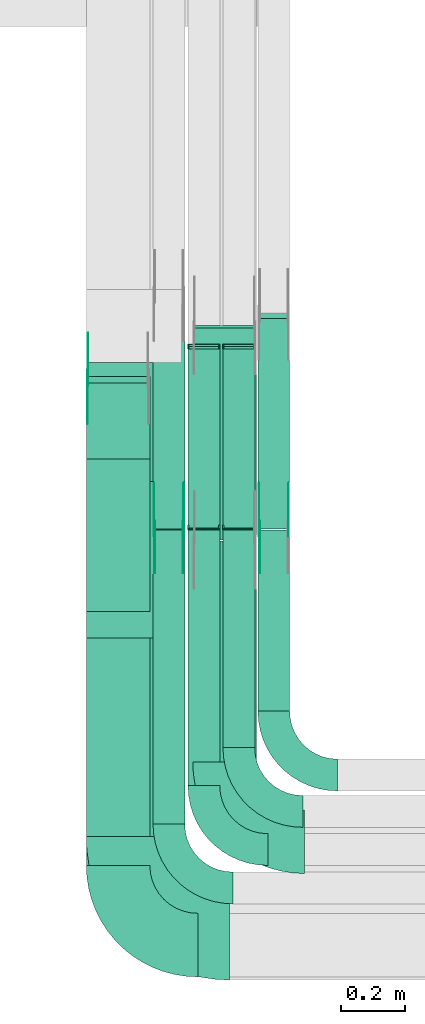
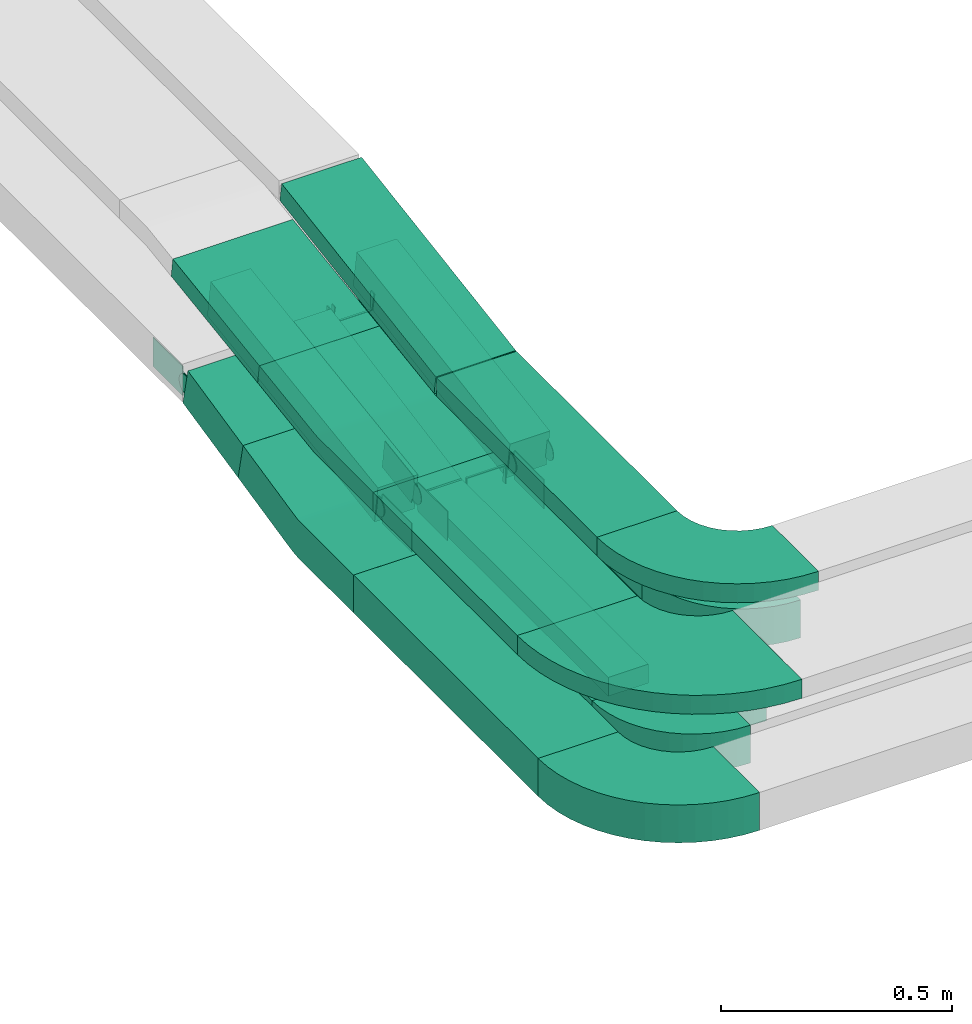
# One storey, part 4 of 28: 22 flow fittings, 14 flow segments.
"""IFC2X3 building model written with IfcOpenShell, lengths in millimetres."""

import ifcopenshell
import ifcopenshell.guid

model = None  # the IFC model being written
_history = None  # IfcOwnerHistory: only IFC2X3 demands one
_inside = {}  # id of a spatial element -> (the spatial element, [elements in it])
_under = {}  # id of a project, library or spatial element -> (it, [spatial elements below it])
_declared = {}  # id of a project -> (the project, [libraries it declares])
_typed = {}  # id of a type object -> (the type object, [elements of that type])
_made_of = {}  # id of a material, layer set ... -> (it, [elements and type objects made of it])


def new_model(schema):
    """Start an empty IFC model of exactly this schema.

    Asked for "IFC4X3", IfcOpenShell would pick the latest addendum, in which some entities
    have other attributes; the version numbers below select the first issue.
    IFC2X3 requires an IfcOwnerHistory on every rooted entity: one is made here for all.
    """
    global model, _history
    if schema == "IFC4X3":
        model = ifcopenshell.file(schema_version=(4, 3, 0, 0))
    else:
        model = ifcopenshell.file(schema=schema)
    _inside.clear()
    _under.clear()
    _declared.clear()
    _typed.clear()
    _made_of.clear()
    _history = None
    if model.schema == "IFC2X3":
        org = make("IfcOrganization", Name="unknown")
        user = make(
            "IfcPersonAndOrganization",
            ThePerson=make("IfcPerson", FamilyName="unknown"),
            TheOrganization=org,
        )
        app = make(
            "IfcApplication",
            ApplicationDeveloper=org,
            Version="unknown",
            ApplicationFullName="unknown",
            ApplicationIdentifier="unknown",
        )
        _history = make(
            "IfcOwnerHistory",
            OwningUser=user,
            OwningApplication=app,
            ChangeAction="ADDED",
            CreationDate=0,
        )
    return model


def make(cls, **values):
    """One entity of the class cls with the attributes given. An attribute that is None is left unset."""
    return model.create_entity(
        cls, **{name: value for name, value in values.items() if value is not None}
    )


def entity(cls, *values):
    """Any entity or typed value of the class cls, its attributes in the order of the schema. None: left unset."""
    e = model.create_entity(cls)
    for i, value in enumerate(values):
        if value is not None:
            e[i] = value
    return e


def rooted(cls, **values):
    """An entity with a GlobalId (a new one), such as an element, a storey or a relation."""
    return make(cls, GlobalId=ifcopenshell.guid.new(), OwnerHistory=_history, **values)


def si_unit(unit_type, name, prefix=None):
    """IfcSIUnit, for example si_unit("LENGTHUNIT", "METRE", prefix="MILLI")."""
    return make("IfcSIUnit", UnitType=unit_type, Prefix=prefix, Name=name)


def converted_unit(unit_type, name, factor, base, dimensions=None, offset=None):
    """IfcConversionBasedUnit, such as the inch: factor (a typed value) times the base unit."""
    return make(
        "IfcConversionBasedUnit"
        if offset is None
        else "IfcConversionBasedUnitWithOffset",
        ConversionOffset=offset,
        Dimensions=None
        if dimensions is None
        else entity("IfcDimensionalExponents", *dimensions),
        UnitType=unit_type,
        Name=name,
        ConversionFactor=make(
            "IfcMeasureWithUnit", ValueComponent=factor, UnitComponent=base
        ),
    )


def derived_unit(unit_type, elements):
    """IfcDerivedUnit: a product of units, each with its exponent."""
    return make(
        "IfcDerivedUnit",
        Elements=[
            make("IfcDerivedUnitElement", Unit=unit, Exponent=power)
            for unit, power in elements
        ],
        UnitType=unit_type,
    )


def assignment(units):
    """IfcUnitAssignment: the units of a project."""
    return None if units is None else make("IfcUnitAssignment", Units=units)


def point(xyz):
    """IfcCartesianPoint."""
    return None if xyz is None else make("IfcCartesianPoint", Coordinates=xyz)


def direction(xyz):
    """IfcDirection."""
    return None if xyz is None else make("IfcDirection", DirectionRatios=xyz)


def frame(location, z_axis=None, x_axis=None):
    """IfcAxis2Placement3D, a coordinate frame: its origin and axes. An axis left out is left unset."""
    return make(
        "IfcAxis2Placement3D",
        Location=point(location),
        Axis=direction(z_axis),
        RefDirection=direction(x_axis),
    )


def frame_2d(location, x_axis=None):
    """IfcAxis2Placement2D, a coordinate frame in the plane: its origin and x axis."""
    return make(
        "IfcAxis2Placement2D", Location=point(location), RefDirection=direction(x_axis)
    )


def origin():
    """The frame at (0, 0, 0) with its axes left unset."""
    return frame((0.0, 0.0, 0.0))


def origin_2d_with_axis():
    """The frame at (0, 0) in the plane with the x axis (1, 0) written out."""
    return frame_2d((0.0, 0.0), x_axis=(1.0, 0.0))


def place(relative_to, where):
    """IfcLocalPlacement: puts the frame where relative to a parent placement (None: the world)."""
    return make(
        "IfcLocalPlacement", PlacementRelTo=relative_to, RelativePlacement=where
    )


def context(
    kind, dimensions, precision=None, world=None, true_north=None, identifier=None
):
    """IfcGeometricRepresentationContext, for example the 3D "Model" context."""
    return make(
        "IfcGeometricRepresentationContext",
        ContextIdentifier=identifier,
        ContextType=kind,
        CoordinateSpaceDimension=dimensions,
        Precision=precision,
        WorldCoordinateSystem=world,
        TrueNorth=true_north,
    )


def subcontext(parent, identifier, kind, view, scale=None):
    """IfcGeometricRepresentationSubContext, for example "Body" below "Model"."""
    return make(
        "IfcGeometricRepresentationSubContext",
        ContextIdentifier=identifier,
        ContextType=kind,
        ParentContext=parent,
        TargetScale=scale,
        TargetView=view,
    )


def project(units=None, contexts=None):
    """IfcProject with its units and contexts."""
    return rooted(
        "IfcProject",
        Name="project",
        RepresentationContexts=contexts,
        UnitsInContext=assignment(units),
    )


def spatial(cls, under=None, at=None, **own):
    """A site, building, storey or space (cls), placed at a placement, below another one or the project."""
    s = rooted(cls, ObjectPlacement=at, **own)
    if under is not None:
        _under.setdefault(under.id(), (under, []))[1].append(s)
    return s


def polyline(points):
    """IfcPolyline through the points."""
    return make("IfcPolyline", Points=[point(p) for p in points])


def circle_curve(where, radius):
    """IfcCircle in the frame where."""
    return make("IfcCircle", Position=where, Radius=radius)


def parameter(value):
    """IfcParameterValue: where a trimmed curve begins or ends, as a parameter of its basis curve."""
    return model.create_entity("IfcParameterValue", value)


def trimmed(basis, trim1, trim2, sense, master):
    """IfcTrimmedCurve: the piece of a basis curve between two trims."""
    return make(
        "IfcTrimmedCurve",
        BasisCurve=basis,
        Trim1=trim1,
        Trim2=trim2,
        SenseAgreement=sense,
        MasterRepresentation=master,
    )


def segment(curve, same_sense, transition):
    """IfcCompositeCurveSegment."""
    return make(
        "IfcCompositeCurveSegment",
        Transition=transition,
        SameSense=same_sense,
        ParentCurve=curve,
    )


def composite_curve(segments, self_intersect=None):
    """IfcCompositeCurve: segments joined end to end."""
    return make("IfcCompositeCurve", Segments=segments, SelfIntersect=self_intersect)


def profile(cls, at=None, kind="AREA", **sizes):
    """A parametric profile (cls). Its sizes go by their IFC names, for example OverallWidth=200.0."""
    return make(cls, ProfileType=kind, Position=at, **sizes)


def rectangle(**sizes):
    """IfcRectangleProfileDef."""
    return profile("IfcRectangleProfileDef", **sizes)


def outline(outer, holes=None, kind="AREA"):
    """IfcArbitraryClosedProfileDef: a profile drawn as a closed curve; with holes, ...WithVoids."""
    if holes is None:
        return make("IfcArbitraryClosedProfileDef", ProfileType=kind, OuterCurve=outer)
    return make(
        "IfcArbitraryProfileDefWithVoids",
        ProfileType=kind,
        OuterCurve=outer,
        InnerCurves=holes,
    )


def extrude(swept, where, along, depth):
    """IfcExtrudedAreaSolid: the profile swept, set in the frame where, extruded along a direction by depth."""
    return make(
        "IfcExtrudedAreaSolid",
        SweptArea=swept,
        Position=where,
        ExtrudedDirection=direction(along),
        Depth=depth,
    )


def faces_of(points, faces, orient=None, outer=None):
    """IfcFace entities. A face is a list of loops; a loop is a list of indices into points, from 0.

    orient and outer hold one flag for each loop. By default every Orientation is true, the
    first loop of a face is its IfcFaceOuterBound and the others are IfcFaceBound.
    """
    made = []
    for i, loops in enumerate(faces):
        bounds = []
        for j, loop in enumerate(loops):
            is_outer = j == 0 if outer is None else outer[i][j]
            bounds.append(
                make(
                    "IfcFaceOuterBound" if is_outer else "IfcFaceBound",
                    Bound=make("IfcPolyLoop", Polygon=[points[k] for k in loop]),
                    Orientation=True if orient is None else orient[i][j],
                )
            )
        made.append(make("IfcFace", Bounds=bounds))
    return made


def faceted_brep(points, faces, orient=None, outer=None, voids=None):
    """IfcFacetedBrep: a solid bounded by flat faces; with voids (closed shells), ...WithVoids."""
    shared = [point(p) for p in points]
    hull = make("IfcClosedShell", CfsFaces=faces_of(shared, faces, orient, outer))
    if voids is None:
        return make("IfcFacetedBrep", Outer=hull)
    return make(
        "IfcFacetedBrepWithVoids",
        Outer=hull,
        Voids=[
            make(cls, CfsFaces=faces_of(shared, fs, o, b)) for cls, fs, o, b in voids
        ],
    )


def shape(context_of_items, identifier, shape_type, items):
    """IfcShapeRepresentation: the items that make up one representation, for example the "Body"."""
    return make(
        "IfcShapeRepresentation",
        ContextOfItems=context_of_items,
        RepresentationIdentifier=identifier,
        RepresentationType=shape_type,
        Items=items,
    )


def source(mapping_origin, context_of_items, identifier, shape_type, items):
    """IfcRepresentationMap: a shape defined once, which mapped items show again and again."""
    return make(
        "IfcRepresentationMap",
        MappingOrigin=mapping_origin,
        MappedRepresentation=shape(context_of_items, identifier, shape_type, items),
    )


def transform(
    local_origin,
    x_axis=None,
    y_axis=None,
    z_axis=None,
    scale=None,
    scale2=None,
    scale3=None,
    uniform=True,
):
    """IfcCartesianTransformationOperator3D, or its non-uniform kind. x_axis, y_axis, z_axis: its Axis1, 2, 3."""
    if uniform:
        return make(
            "IfcCartesianTransformationOperator3D",
            Axis1=direction(x_axis),
            Axis2=direction(y_axis),
            LocalOrigin=point(local_origin),
            Scale=scale,
            Axis3=direction(z_axis),
        )
    return make(
        "IfcCartesianTransformationOperator3DnonUniform",
        Axis1=direction(x_axis),
        Axis2=direction(y_axis),
        LocalOrigin=point(local_origin),
        Scale=scale,
        Axis3=direction(z_axis),
        Scale2=scale2,
        Scale3=scale3,
    )


def mapped(mapping_source, mapping_target):
    """IfcMappedItem: shows the shape of a source again, moved by a transform."""
    return make(
        "IfcMappedItem", MappingSource=mapping_source, MappingTarget=mapping_target
    )


def material(Name=None, Category=None):
    """IfcMaterial."""
    return make("IfcMaterial", Name=Name, Category=Category)


def made_of(thing, what):
    """Note that an element or type object is made of a material, layer set ...; save() writes the relation."""
    if what is not None:
        _made_of.setdefault(what.id(), (what, []))[1].append(thing)
    return thing


def type_object(cls, material=None, **own):
    """A type object (cls), such as IfcWallType, which elements share."""
    return made_of(rooted(cls, **own), material)


def type_shapes(of_type, sources):
    """Give a type object the sources (RepresentationMaps) that its elements show as mapped items."""
    of_type.RepresentationMaps = sources


def element(
    cls,
    number,
    at=None,
    inside=None,
    cuts=None,
    type_object=None,
    material=None,
    context=None,
    identifier="Body",
    shape_type=None,
    held_by="IfcProductDefinitionShape",
    body=None,
    shapes=None,
    **own,
):
    """One element of the class cls, such as IfcWall. Its Tag is "e" and its number.

    at: its placement. inside: the storey or other place that contains it. cuts: it is an
    opening in that element (IfcRelVoidsElement). A single representation is given by context,
    identifier, shape_type and body (its items); several are given by shapes. held_by: the class
    of the entity that holds the representations. save() writes the other relations.
    """
    e = rooted(cls, Tag="e%d" % number, ObjectPlacement=at, **own)
    if body is not None:
        shapes = [shape(context, identifier, shape_type, body)]
    if shapes is not None:
        e.Representation = make(held_by, Representations=shapes)
    if inside is not None:
        _inside.setdefault(inside.id(), (inside, []))[1].append(e)
    if cuts is not None:
        rooted(
            "IfcRelVoidsElement", RelatingBuildingElement=cuts, RelatedOpeningElement=e
        )
    if type_object is not None:
        _typed.setdefault(type_object.id(), (type_object, []))[1].append(e)
    return made_of(e, material)


def aggregate(whole, parts):
    """IfcRelAggregates: a whole, such as a stair, and the parts it consists of."""
    return rooted("IfcRelAggregates", RelatingObject=whole, RelatedObjects=parts)


def save(model, path):
    """Write the relations noted so far, then the file.

    IfcRelAggregates (storeys below a building ...), IfcRelContainedInSpatialStructure (elements
    in a storey), IfcRelDefinesByType, IfcRelAssociatesMaterial and IfcRelDeclares: one each for
    every whole, place, type object, material and project.
    """
    for whole, parts in _under.values():
        aggregate(whole, parts)
    for where, things in _inside.values():
        rooted(
            "IfcRelContainedInSpatialStructure",
            RelatedElements=things,
            RelatingStructure=where,
        )
    for kind, things in _typed.values():
        rooted("IfcRelDefinesByType", RelatedObjects=things, RelatingType=kind)
    for what, things in _made_of.values():
        rooted("IfcRelAssociatesMaterial", RelatedObjects=things, RelatingMaterial=what)
    for by, libraries in _declared.values():
        rooted("IfcRelDeclares", RelatingContext=by, RelatedDefinitions=libraries)
    model.write(path)


model = new_model("IFC2X3")

# Units and contexts
model_context = context("Model", 3, precision=0.01, world=origin(), true_north=direction((6.12303176911189e-17, 1.0)))
body_context = subcontext(model_context, "Body", "Model", "MODEL_VIEW")
ifc_project = project(units=[si_unit("LENGTHUNIT", "METRE", prefix="MILLI"), si_unit("AREAUNIT", "SQUARE_METRE"), si_unit("VOLUMEUNIT", "CUBIC_METRE"), converted_unit("PLANEANGLEUNIT", "DEGREE", entity("IfcRatioMeasure", 0.0174532925199433), si_unit("PLANEANGLEUNIT", "RADIAN"), dimensions=[0, 0, 0, 0, 0, 0, 0]), si_unit("MASSUNIT", "GRAM", prefix="KILO"), derived_unit("MASSDENSITYUNIT", [(si_unit("MASSUNIT", "GRAM", prefix="KILO"), 1), (si_unit("LENGTHUNIT", "METRE"), -3)]), derived_unit("MOMENTOFINERTIAUNIT", [(si_unit("LENGTHUNIT", "METRE"), 4)]), si_unit("TIMEUNIT", "SECOND"), si_unit("FREQUENCYUNIT", "HERTZ"), si_unit("THERMODYNAMICTEMPERATUREUNIT", "DEGREE_CELSIUS"), derived_unit("THERMALTRANSMITTANCEUNIT", [(si_unit("MASSUNIT", "GRAM", prefix="KILO"), 1), (si_unit("THERMODYNAMICTEMPERATUREUNIT", "KELVIN"), -1), (si_unit("TIMEUNIT", "SECOND"), -3)]), derived_unit("VOLUMETRICFLOWRATEUNIT", [(si_unit("LENGTHUNIT", "METRE"), 3), (si_unit("TIMEUNIT", "SECOND"), -1)]), derived_unit("MASSFLOWRATEUNIT", [(si_unit("MASSUNIT", "GRAM", prefix="KILO"), 1), (si_unit("TIMEUNIT", "SECOND"), -1)]), derived_unit("ROTATIONALFREQUENCYUNIT", [(si_unit("TIMEUNIT", "SECOND"), -1)]), si_unit("ELECTRICCURRENTUNIT", "AMPERE"), si_unit("ELECTRICVOLTAGEUNIT", "VOLT"), si_unit("POWERUNIT", "WATT"), si_unit("FORCEUNIT", "NEWTON", prefix="KILO"), si_unit("ILLUMINANCEUNIT", "LUX"), si_unit("LUMINOUSFLUXUNIT", "LUMEN"), si_unit("LUMINOUSINTENSITYUNIT", "CANDELA"), derived_unit("USERDEFINED", [(si_unit("MASSUNIT", "GRAM", prefix="KILO"), -1), (si_unit("LENGTHUNIT", "METRE"), -2), (si_unit("TIMEUNIT", "SECOND"), 3), (si_unit("LUMINOUSFLUXUNIT", "LUMEN"), 1)]), derived_unit("LINEARVELOCITYUNIT", [(si_unit("LENGTHUNIT", "METRE"), 1), (si_unit("TIMEUNIT", "SECOND"), -1)]), si_unit("PRESSUREUNIT", "PASCAL"), derived_unit("USERDEFINED", [(si_unit("LENGTHUNIT", "METRE"), -2), (si_unit("MASSUNIT", "GRAM", prefix="KILO"), 1), (si_unit("TIMEUNIT", "SECOND"), -2)]), derived_unit("LINEARFORCEUNIT", [(si_unit("MASSUNIT", "GRAM", prefix="KILO"), 1), (si_unit("LENGTHUNIT", "METRE"), 1), (si_unit("TIMEUNIT", "SECOND"), -2), (si_unit("LENGTHUNIT", "METRE"), -1)]), derived_unit("PLANARFORCEUNIT", [(si_unit("MASSUNIT", "GRAM", prefix="KILO"), 1), (si_unit("LENGTHUNIT", "METRE"), 1), (si_unit("TIMEUNIT", "SECOND"), -2), (si_unit("LENGTHUNIT", "METRE"), -2)])], contexts=[model_context])

# Site, building, storey
site_placement = place(None, origin())
site = spatial("IfcSite", under=ifc_project, at=site_placement, CompositionType="ELEMENT")
building_placement = place(site_placement, origin())
building = spatial("IfcBuilding", under=site, at=building_placement, CompositionType="ELEMENT")
storey_placement = place(building_placement, frame((0.0, 0.0, 15900.0)))
storey = spatial("IfcBuildingStorey", under=building, at=storey_placement, CompositionType="ELEMENT", Elevation=15900.0)

# Flow segments
cable_carrier_segment_type = type_object("IfcCableCarrierSegmentType", PredefinedType="CABLETRAYSEGMENT")
flow_segment_1_placement = place(storey_placement, frame((16533.5, 9853.45, 2554.37)))
element("IfcFlowSegment", 1, at=flow_segment_1_placement, inside=storey, type_object=cable_carrier_segment_type, context=body_context, shape_type="SweptSolid", body=[
    extrude(rectangle(XDim=100.000000000001, YDim=244.622531681312, at=frame_2d((0.0, 0.0), x_axis=(0.0, 1.0))), frame((0.0, 130.2, 75.12), z_axis=(1.0, 0.0, 0.0), x_axis=(0.0, 0.976627229070763, 0.214940120586091)), (0.0, 0.0, 1.0), 200.0),
])
flow_segment_2_placement = place(storey_placement, frame((16743.5, 9633.37, 2501.24)))
element("IfcFlowSegment", 2, at=flow_segment_2_placement, inside=storey, type_object=cable_carrier_segment_type, context=body_context, shape_type="SweptSolid", body=[
    extrude(rectangle(XDim=100.000000000002, YDim=99.9999999999989, at=frame_2d((0.0, 0.0), x_axis=(0.0, 1.0))), frame((50.0, 7.23, 49.47), z_axis=(0.0, 0.989493546804659, 0.144577041164689), x_axis=(-1.0, 0.0, 0.0)), (0.0, 0.0, 1.0), 732.026327691684),
])
flow_segment_3_placement = place(storey_placement, frame((16853.5, 9635.69, 2501.28)))
element("IfcFlowSegment", 3, at=flow_segment_3_placement, inside=storey, type_object=cable_carrier_segment_type, context=body_context, shape_type="SweptSolid", body=[
    extrude(rectangle(XDim=49.9999999999998, YDim=574.752456926632, at=frame_2d((0.0, 0.0), x_axis=(0.0, 1.0))), frame((0.0, 287.08, 77.35), z_axis=(1.0, 0.0, 0.0), x_axis=(0.0, 0.982990459480717, 0.183656626806355)), (0.0, 0.0, 1.0), 99.9999999999989),
])
flow_segment_4_placement = place(storey_placement, frame((16963.5, 9635.69, 2501.28)))
element("IfcFlowSegment", 4, at=flow_segment_4_placement, inside=storey, type_object=cable_carrier_segment_type, context=body_context, shape_type="SweptSolid", body=[
    extrude(rectangle(XDim=49.9999999999998, YDim=574.752456926633, at=frame_2d((0.0, 0.0), x_axis=(0.0, 1.0))), frame((0.0, 287.08, 77.35), z_axis=(1.0, 0.0, 0.0), x_axis=(0.0, 0.982990459480717, 0.183656626806355)), (0.0, 0.0, 1.0), 99.9999999999989),
])
flow_segment_5_placement = place(storey_placement, frame((17073.5, 9633.08, 2501.45)))
element("IfcFlowSegment", 5, at=flow_segment_5_placement, inside=storey, type_object=cable_carrier_segment_type, context=body_context, shape_type="SweptSolid", body=[
    extrude(rectangle(XDim=99.9999999999983, YDim=672.021585720091, at=frame_2d((0.0, 0.0), x_axis=(0.0, 1.0))), frame((0.0, 339.69, 102.18), z_axis=(1.0, 0.0, 0.0), x_axis=(0.0, 0.987576211285327, 0.157140786886536)), (0.0, 0.0, 1.0), 99.9999999999989),
])
flow_segment_6_placement = place(storey_placement, frame((16533.5, 8575.97, 2500.0)))
element("IfcFlowSegment", 6, at=flow_segment_6_placement, inside=storey, type_object=cable_carrier_segment_type, context=body_context, shape_type="SweptSolid", body=[
    extrude(rectangle(XDim=798.975695122896, YDim=200.000000000002, at=origin_2d_with_axis()), frame((100.0, 399.49, 0.0), z_axis=(0.0, 0.0, 1.0), x_axis=(0.0, -1.0, 0.0)), (0.0, 0.0, 1.0), 99.9999999999989),
])
flow_segment_7_placement = place(storey_placement, frame((16743.5, 8705.97, 2500.0)))
element("IfcFlowSegment", 7, at=flow_segment_7_placement, inside=storey, type_object=cable_carrier_segment_type, context=body_context, shape_type="SweptSolid", body=[
    extrude(rectangle(XDim=924.84066225427, YDim=99.9999999999989, at=origin_2d_with_axis()), frame((50.0, 462.42, 0.0), z_axis=(0.0, 0.0, 1.0), x_axis=(0.0, -1.0, 0.0)), (0.0, 0.0, 1.0), 99.9999999999989),
])
flow_segment_8_placement = place(storey_placement, frame((16853.5, 8826.5, 2500.0)))
element("IfcFlowSegment", 8, at=flow_segment_8_placement, inside=storey, type_object=cable_carrier_segment_type, context=body_context, shape_type="SweptSolid", body=[
    extrude(rectangle(XDim=804.598148550835, YDim=99.9999999999989, at=origin_2d_with_axis()), frame((50.0, 402.3, 0.0), z_axis=(0.0, 0.0, 1.0), x_axis=(0.0, -1.0, 0.0)), (0.0, 0.0, 1.0), 50.0000000000016),
])
flow_segment_9_placement = place(storey_placement, frame((16963.5, 8946.5, 2500.0)))
element("IfcFlowSegment", 9, at=flow_segment_9_placement, inside=storey, type_object=cable_carrier_segment_type, context=body_context, shape_type="SweptSolid", body=[
    extrude(rectangle(XDim=684.598148550835, YDim=99.9999999999989, at=origin_2d_with_axis()), frame((50.0, 342.3, 0.0), z_axis=(0.0, 0.0, 1.0), x_axis=(0.0, -1.0, 0.0)), (0.0, 0.0, 1.0), 49.9999999999995),
])
flow_segment_10_placement = place(storey_placement, frame((17073.5, 9060.97, 2500.0)))
element("IfcFlowSegment", 10, at=flow_segment_10_placement, inside=storey, type_object=cable_carrier_segment_type, context=body_context, shape_type="SweptSolid", body=[
    extrude(rectangle(XDim=569.495535228138, YDim=99.9999999999989, at=origin_2d_with_axis()), frame((50.0, 284.75, 0.0), z_axis=(0.0, 0.0, 1.0), x_axis=(0.0, -1.0, 0.0)), (0.0, 0.0, 1.0), 99.9999999999989),
])
flow_segment_11_placement = place(storey_placement, frame((16868.5, 8901.15, 2820.0)))
element("IfcFlowSegment", 11, at=flow_segment_11_placement, inside=storey, type_object=cable_carrier_segment_type, context=body_context, shape_type="SweptSolid", body=[
    extrude(rectangle(XDim=695.282073093832, YDim=200.000000000002, at=origin_2d_with_axis()), frame((100.0, 347.64, 0.0), z_axis=(0.0, 0.0, 1.0), x_axis=(0.0, 1.0, 0.0)), (0.0, 0.0, 1.0), 50.0000000000038),
])
flow_segment_12_placement = place(storey_placement, frame((16533.5, 8666.15, 2820.0)))
element("IfcFlowSegment", 12, at=flow_segment_12_placement, inside=storey, type_object=cable_carrier_segment_type, context=body_context, shape_type="SweptSolid", body=[
    extrude(rectangle(XDim=624.071371704514, YDim=300.000000000001, at=origin_2d_with_axis()), frame((150.0, 312.04, 0.0), z_axis=(0.0, 0.0, 1.0), x_axis=(0.0, -1.0, 0.0)), (0.0, 0.0, 1.0), 50.0000000000016),
])
flow_segment_13_placement = place(storey_placement, frame((16533.5, 9782.99, 2856.34)))
element("IfcFlowSegment", 13, at=flow_segment_13_placement, inside=storey, type_object=cable_carrier_segment_type, context=body_context, shape_type="SweptSolid", body=[
    extrude(rectangle(XDim=50.0000000000014, YDim=378.580677399284, at=frame_2d((0.0, 0.0), x_axis=(0.0, 1.0))), frame((0.0, 190.92, 52.1), z_axis=(1.0, 0.0, 0.0), x_axis=(0.0, 0.98949354680465, 0.144577041164753)), (0.0, 0.0, 1.0), 299.999999999999),
])
flow_segment_14_placement = place(storey_placement, frame((16868.5, 9599.05, 2820.83)))
element("IfcFlowSegment", 14, at=flow_segment_14_placement, inside=storey, type_object=cable_carrier_segment_type, context=body_context, shape_type="SweptSolid", body=[
    extrude(rectangle(XDim=50.0000000000019, YDim=675.974661481006, at=frame_2d((0.0, 0.0), x_axis=(0.0, 1.0))), frame((0.0, 337.72, 77.8), z_axis=(1.0, 0.0, 0.0), x_axis=(0.0, -0.987576211285318, -0.157140786886588)), (0.0, 0.0, 1.0), 199.999999999998),
])

# Flow fittings
ifc_material_1 = material()
cable_carrier_fitting_type_1 = type_object("IfcCableCarrierFittingType", PredefinedType="NOTDEFINED", material=ifc_material_1)
shared_shape_1 = source(origin(), body_context, "Body", "Brep", [
    faceted_brep([(-4.63, 25.0, 50.0), (-4.63, 25.0, -50.0), (-4.63, -25.0, -50.0), (-4.63, -25.0, -47.46), (-4.63, 22.46, -47.46), (-4.63, 22.46, 47.46), (-4.63, -25.0, 47.46), (-4.63, -25.0, 50.0), (-0.04, 25.43, 50.0), (9.14, -23.72, 50.0), (9.14, -23.72, 47.46), (0.43, 22.93, 47.46), (0.43, 22.93, -47.46), (9.14, -23.72, -47.46), (9.14, -23.72, -50.0), (-0.04, 25.43, -50.0), (-2.32, 25.0, 50.0), (-2.32, 25.0, -50.0), (2.32, -25.0, -50.0), (2.32, -25.0, -47.46), (-2.08, 22.46, -47.46), (-2.08, 22.46, 47.46), (2.32, -25.0, 47.46), (2.32, -25.0, 50.0)], [[[0, 1, 2, 3, 4, 5, 6, 7]], [[8, 9, 10, 11, 12, 13, 14, 15]], [[1, 0, 16, 17]], [[2, 1, 17, 15, 14, 18]], [[3, 2, 18, 19]], [[4, 3, 19, 13, 12, 20]], [[5, 4, 20, 21]], [[6, 5, 21, 11, 10, 22]], [[7, 6, 22, 23]], [[0, 7, 23, 9, 8, 16]], [[17, 16, 8, 15]], [[19, 18, 14, 13]], [[21, 20, 12, 11]], [[23, 22, 10, 9]]]),
])
type_shapes(cable_carrier_fitting_type_1, [shared_shape_1])
for number, where, z_axis, x_axis in (
    (15, (16903.5, 9635.73, 2525.0), (1.0, 0.0, 0.0), (0.0, 1.0, 0.0)),
    (16, (16903.5, 10209.81, 2632.26), (1.0, 0.0, 0.0), (0.0, -1.0, 0.0)),
    (17, (17013.5, 9635.73, 2525.0), (1.0, 0.0, 0.0), (0.0, 1.0, 0.0)),
    (18, (17013.5, 10209.81, 2632.26), (1.0, 0.0, 0.0), (0.0, -1.0, 0.0)),
):
    element("IfcFlowFitting", number, at=place(storey_placement, frame(where, z_axis=z_axis, x_axis=x_axis)), inside=storey, type_object=cable_carrier_fitting_type_1, material=ifc_material_1, context=body_context, shape_type="MappedRepresentation", body=[
        mapped(shared_shape_1, transform((0.0, 0.0, 0.0), scale=1.0)),
    ])
cable_carrier_fitting_type_2 = type_object("IfcCableCarrierFittingType", Name="470_DKC_S5_Variable Angle Elbow 0-45:-", PredefinedType="NOTDEFINED", material=ifc_material_1)
shared_shape_2 = source(origin(), body_context, "Body", "SweptSolid", [
    extrude(outline(composite_curve([segment(polyline([(-150.75, -300.25), (-149.75, -300.25)]), True, "CONTINUOUS"), segment(trimmed(circle_curve(frame_2d((-149.75, 149.75), x_axis=(0.0, -1.0)), 450.0), [parameter(0.0)], [parameter(90.0000000000001)], True, "PARAMETER"), True, "CONTINUOUS"), segment(polyline([(300.25, 149.75), (300.25, 150.75)]), True, "CONTINUOUS"), segment(polyline([(300.25, 150.75), (0.25, 150.75)]), True, "CONTINUOUS"), segment(polyline([(0.25, 150.75), (0.25, 149.75)]), True, "CONTINUOUS"), segment(trimmed(circle_curve(frame_2d((-149.75, 149.75), x_axis=(0.0, -1.0)), 150.0), [parameter(0.0)], [parameter(90.0000000000001)], True, "PARAMETER"), False, "CONTINUOUS"), segment(polyline([(-149.75, -0.25), (-150.75, -0.25)]), True, "CONTINUOUS"), segment(polyline([(-150.75, -0.25), (-150.75, -300.25)]), True, "CONTINUOUS")], self_intersect=False)), frame((-150.25, 150.25, -25.0)), (0.0, 0.0, 1.0), 49.9999999999974),
])
type_shapes(cable_carrier_fitting_type_2, [shared_shape_2])
flow_fitting_1_placement = place(storey_placement, frame((16683.5, 8365.15, 2845.0), z_axis=(0.0, 0.0, 1.0), x_axis=(0.0, -1.0, 0.0)))
element("IfcFlowFitting", 19, at=flow_fitting_1_placement, inside=storey, type_object=cable_carrier_fitting_type_2, material=ifc_material_1, Name="470_DKC_S5_Variable Angle Elbow 0-45:-", ObjectType="470_DKC_S5_Variable Angle Elbow 0-45:-", context=body_context, shape_type="MappedRepresentation", body=[
    mapped(shared_shape_2, transform((0.0, 0.0, 0.0), scale=1.0)),
])
cable_carrier_fitting_type_3 = type_object("IfcCableCarrierFittingType", Name="470_DKC_S5_Variable Angle Elbow 0-45:-", PredefinedType="NOTDEFINED", material=ifc_material_1)
shared_shape_3 = source(origin(), body_context, "Body", "SweptSolid", [
    extrude(outline(composite_curve([segment(polyline([(-125.75, -225.25), (-124.75, -225.25)]), True, "CONTINUOUS"), segment(trimmed(circle_curve(frame_2d((-124.75, 124.75), x_axis=(0.0, -1.0)), 350.0), [parameter(0.0)], [parameter(90.0000000000001)], True, "PARAMETER"), True, "CONTINUOUS"), segment(polyline([(225.25, 124.75), (225.25, 125.75)]), True, "CONTINUOUS"), segment(polyline([(225.25, 125.75), (25.25, 125.75)]), True, "CONTINUOUS"), segment(polyline([(25.25, 125.75), (25.25, 124.75)]), True, "CONTINUOUS"), segment(trimmed(circle_curve(frame_2d((-124.75, 124.75), x_axis=(0.0, -1.0)), 150.0), [parameter(0.0)], [parameter(90.0000000000001)], True, "PARAMETER"), False, "CONTINUOUS"), segment(polyline([(-124.75, -25.25), (-125.75, -25.25)]), True, "CONTINUOUS"), segment(polyline([(-125.75, -25.25), (-125.75, -225.25)]), True, "CONTINUOUS")], self_intersect=False)), frame((-125.25, 125.25, -50.0)), (0.0, 0.0, 1.0), 100.0),
])
type_shapes(cable_carrier_fitting_type_3, [shared_shape_3])
flow_fitting_2_placement = place(storey_placement, frame((16633.5, 8324.97, 2550.0), z_axis=(0.0, 0.0, 1.0), x_axis=(0.0, -1.0, 0.0)))
element("IfcFlowFitting", 20, at=flow_fitting_2_placement, inside=storey, type_object=cable_carrier_fitting_type_3, material=ifc_material_1, Name="470_DKC_S5_Variable Angle Elbow 0-45:-", ObjectType="470_DKC_S5_Variable Angle Elbow 0-45:-", context=body_context, shape_type="MappedRepresentation", body=[
    mapped(shared_shape_3, transform((0.0, 0.0, 0.0), scale=1.0)),
])
cable_carrier_fitting_type_4 = type_object("IfcCableCarrierFittingType", Name="470_DKC_S5_Variable Angle Elbow 0-45:-", PredefinedType="NOTDEFINED", material=ifc_material_1)
shared_shape_4 = source(origin(), body_context, "Body", "SweptSolid", [
    extrude(outline(composite_curve([segment(polyline([(-100.75, -150.25), (-99.75, -150.25)]), True, "CONTINUOUS"), segment(trimmed(circle_curve(frame_2d((-99.75, 99.75), x_axis=(0.0, -1.0)), 250.0), [parameter(0.0)], [parameter(90.0000000000001)], True, "PARAMETER"), True, "CONTINUOUS"), segment(polyline([(150.25, 99.75), (150.25, 100.75)]), True, "CONTINUOUS"), segment(polyline([(150.25, 100.75), (50.25, 100.75)]), True, "CONTINUOUS"), segment(polyline([(50.25, 100.75), (50.25, 99.75)]), True, "CONTINUOUS"), segment(trimmed(circle_curve(frame_2d((-99.75, 99.75), x_axis=(0.0, -1.0)), 150.0), [parameter(0.0)], [parameter(90.0000000000001)], True, "PARAMETER"), False, "CONTINUOUS"), segment(polyline([(-99.75, -50.25), (-100.75, -50.25)]), True, "CONTINUOUS"), segment(polyline([(-100.75, -50.25), (-100.75, -150.25)]), True, "CONTINUOUS")], self_intersect=False)), frame((-100.25, 100.25, -25.0)), (0.0, 0.0, 1.0), 49.9999999999997),
])
type_shapes(cable_carrier_fitting_type_4, [shared_shape_4])
for number, where, z_axis, x_axis, name in (
    (21, (16903.5, 8625.5, 2525.0), (0.0, 0.0, 1.0), (0.0, -1.0, 0.0), "470_DKC_S5_Variable Angle Elbow 0-45:-"),
    (22, (17013.5, 8745.5, 2525.0), (0.0, 0.0, 1.0), (0.0, -1.0, 0.0), "470_DKC_S5_Variable Angle Elbow 0-45:-"),
):
    element("IfcFlowFitting", number, at=place(storey_placement, frame(where, z_axis=z_axis, x_axis=x_axis)), inside=storey, type_object=cable_carrier_fitting_type_4, material=ifc_material_1, Name=name, ObjectType="470_DKC_S5_Variable Angle Elbow 0-45:-", context=body_context, shape_type="MappedRepresentation", body=[
        mapped(shared_shape_4, transform((0.0, 0.0, 0.0), scale=1.0)),
    ])
cable_carrier_fitting_type_5 = type_object("IfcCableCarrierFittingType", Name="470_DKC_S5_Variable Angle Elbow 0-45:-", PredefinedType="NOTDEFINED", material=ifc_material_1)
shared_shape_5 = source(origin(), body_context, "Body", "SweptSolid", [
    extrude(outline(composite_curve([segment(polyline([(-100.75, -150.25), (-99.75, -150.25)]), True, "CONTINUOUS"), segment(trimmed(circle_curve(frame_2d((-99.75, 99.75), x_axis=(0.0, -1.0)), 250.0), [parameter(0.0)], [parameter(90.0000000000001)], True, "PARAMETER"), True, "CONTINUOUS"), segment(polyline([(150.25, 99.75), (150.25, 100.75)]), True, "CONTINUOUS"), segment(polyline([(150.25, 100.75), (50.25, 100.75)]), True, "CONTINUOUS"), segment(polyline([(50.25, 100.75), (50.25, 99.75)]), True, "CONTINUOUS"), segment(trimmed(circle_curve(frame_2d((-99.75, 99.75), x_axis=(0.0, -1.0)), 150.0), [parameter(0.0)], [parameter(90.0000000000001)], True, "PARAMETER"), False, "CONTINUOUS"), segment(polyline([(-99.75, -50.25), (-100.75, -50.25)]), True, "CONTINUOUS"), segment(polyline([(-100.75, -50.25), (-100.75, -150.25)]), True, "CONTINUOUS")], self_intersect=False)), frame((-100.25, 100.25, -50.0)), (0.0, 0.0, 1.0), 100.0),
])
type_shapes(cable_carrier_fitting_type_5, [shared_shape_5])
for number, where, z_axis, x_axis, name in (
    (23, (16793.5, 8504.97, 2550.0), (0.0, 0.0, 1.0), (0.0, -1.0, 0.0), "470_DKC_S5_Variable Angle Elbow 0-45:-"),
    (24, (17123.5, 8859.97, 2550.0), (0.0, 0.0, 1.0), (0.0, -1.0, 0.0), "470_DKC_S5_Variable Angle Elbow 0-45:-"),
):
    element("IfcFlowFitting", number, at=place(storey_placement, frame(where, z_axis=z_axis, x_axis=x_axis)), inside=storey, type_object=cable_carrier_fitting_type_5, material=ifc_material_1, Name=name, ObjectType="470_DKC_S5_Variable Angle Elbow 0-45:-", context=body_context, shape_type="MappedRepresentation", body=[
        mapped(shared_shape_5, transform((0.0, 0.0, 0.0), scale=1.0)),
    ])
cable_carrier_fitting_type_6 = type_object("IfcCableCarrierFittingType", Name="470_DKC_S5_Variable Angle Elbow 0-45:-", PredefinedType="NOTDEFINED", material=ifc_material_1)
shared_shape_6 = source(origin(), body_context, "Body", "SweptSolid", [
    extrude(outline(composite_curve([segment(polyline([(-125.75, -225.25), (-124.75, -225.25)]), True, "CONTINUOUS"), segment(trimmed(circle_curve(frame_2d((-124.75, 124.75), x_axis=(0.0, -1.0)), 350.0), [parameter(0.0)], [parameter(90.0)], True, "PARAMETER"), True, "CONTINUOUS"), segment(polyline([(225.25, 124.75), (225.25, 125.75)]), True, "CONTINUOUS"), segment(polyline([(225.25, 125.75), (25.25, 125.75)]), True, "CONTINUOUS"), segment(polyline([(25.25, 125.75), (25.25, 124.75)]), True, "CONTINUOUS"), segment(trimmed(circle_curve(frame_2d((-124.75, 124.75), x_axis=(0.0, -1.0)), 150.0), [parameter(0.0)], [parameter(90.0)], True, "PARAMETER"), False, "CONTINUOUS"), segment(polyline([(-124.75, -25.25), (-125.75, -25.25)]), True, "CONTINUOUS"), segment(polyline([(-125.75, -25.25), (-125.75, -225.25)]), True, "CONTINUOUS")], self_intersect=False)), frame((-125.25, 125.25, -25.0)), (0.0, 0.0, 1.0), 50.000000000001),
])
type_shapes(cable_carrier_fitting_type_6, [shared_shape_6])
flow_fitting_3_placement = place(storey_placement, frame((16968.5, 8650.15, 2845.0), z_axis=(0.0, 0.0, 1.0), x_axis=(0.0, -1.0, 0.0)))
element("IfcFlowFitting", 25, at=flow_fitting_3_placement, inside=storey, type_object=cable_carrier_fitting_type_6, material=ifc_material_1, Name="470_DKC_S5_Variable Angle Elbow 0-45:-", ObjectType="470_DKC_S5_Variable Angle Elbow 0-45:-", context=body_context, shape_type="MappedRepresentation", body=[
    mapped(shared_shape_6, transform((0.0, 0.0, 0.0), scale=1.0)),
])
ifc_material_2 = material(Name="G")
cable_carrier_fitting_type_7 = type_object("IfcCableCarrierFittingType", PredefinedType="NOTDEFINED", material=ifc_material_2)
shared_shape_7 = source(origin(), body_context, "Body", "SweptSolid", [
    extrude(outline(composite_curve([segment(trimmed(circle_curve(frame_2d((-41.47, 0.0), x_axis=(1.0, 0.0)), 25.0), [parameter(90.0000000000007)], [parameter(270.0)], True, "PARAMETER"), True, "CONTINUOUS"), segment(polyline([(-41.47, -25.0), (-29.97, -25.0)]), True, "CONTINUOUS"), segment(polyline([(-29.97, -25.0), (-28.1, -38.5)]), True, "CONTINUOUS"), segment(polyline([(-28.1, -38.5), (99.53, -38.5)]), True, "CONTINUOUS"), segment(polyline([(99.53, -38.5), (99.53, 38.5)]), True, "CONTINUOUS"), segment(polyline([(99.53, 38.5), (-28.1, 38.5)]), True, "CONTINUOUS"), segment(polyline([(-28.1, 38.5), (-29.97, 25.0)]), True, "CONTINUOUS"), segment(polyline([(-29.97, 25.0), (-41.47, 25.0)]), True, "CONTINUOUS")], self_intersect=False)), frame((41.47, 0.0, 0.0), z_axis=(0.0, 0.0, -1.0), x_axis=(1.0, 0.0, 0.0)), (0.0, 0.0, -1.0), 2.0),
])
type_shapes(cable_carrier_fitting_type_7, [shared_shape_7])
flow_fitting_4_placement = place(storey_placement, frame((16838.96, 9635.73, 2550.0), z_axis=(1.0, 0.0, 0.0), x_axis=(0.0, 0.989493546804656, 0.144577041164712)))
element("IfcFlowFitting", 26, at=flow_fitting_4_placement, inside=storey, type_object=cable_carrier_fitting_type_7, material=ifc_material_2, context=body_context, shape_type="MappedRepresentation", body=[
    mapped(shared_shape_7, transform((0.0, 0.0, 0.0), scale=1.0)),
])
cable_carrier_fitting_type_8 = type_object("IfcCableCarrierFittingType", PredefinedType="NOTDEFINED", material=ifc_material_2)
type_shapes(cable_carrier_fitting_type_8, [shared_shape_7])
flow_fitting_5_placement = place(storey_placement, frame((16750.04, 9635.73, 2550.0), z_axis=(-1.0, 0.0, 0.0), x_axis=(0.0, -1.0, 0.0)))
element("IfcFlowFitting", 27, at=flow_fitting_5_placement, inside=storey, type_object=cable_carrier_fitting_type_8, material=ifc_material_2, context=body_context, shape_type="MappedRepresentation", body=[
    mapped(shared_shape_7, transform((0.0, 0.0, 0.0), scale=1.0)),
])
flow_fitting_6_placement = place(storey_placement, frame((17168.96, 9635.73, 2550.0), z_axis=(1.0, 0.0, 0.0), x_axis=(0.0, 0.987576211285325, 0.15714078688655)))
element("IfcFlowFitting", 28, at=flow_fitting_6_placement, inside=storey, type_object=cable_carrier_fitting_type_7, material=ifc_material_2, context=body_context, shape_type="MappedRepresentation", body=[
    mapped(shared_shape_7, transform((0.0, 0.0, 0.0), scale=1.0)),
])
for number, where, z_axis, x_axis in (
    (29, (17080.04, 9635.73, 2550.0), (-1.0, 0.0, 0.0), (0.0, -1.0, 0.0)),
    (30, (16540.04, 10109.81, 2657.26), (-1.0, 0.0, 0.0), (0.0, 1.0, 0.0)),
):
    element("IfcFlowFitting", number, at=place(storey_placement, frame(where, z_axis=z_axis, x_axis=x_axis)), inside=storey, type_object=cable_carrier_fitting_type_8, material=ifc_material_2, context=body_context, shape_type="MappedRepresentation", body=[
        mapped(shared_shape_7, transform((0.0, 0.0, 0.0), scale=1.0)),
    ])
cable_carrier_fitting_type_9 = type_object("IfcCableCarrierFittingType", PredefinedType="NOTDEFINED", material=ifc_material_2)
shared_shape_8 = source(origin(), body_context, "Body", "SweptSolid", [
    extrude(outline(composite_curve([segment(trimmed(circle_curve(frame_2d((-41.47, 0.0), x_axis=(1.0, 0.0)), 25.0), [parameter(90.0000000000007)], [parameter(270.0)], True, "PARAMETER"), True, "CONTINUOUS"), segment(polyline([(-41.47, -25.0), (-29.97, -25.0)]), True, "CONTINUOUS"), segment(polyline([(-29.97, -25.0), (-28.1, -38.5)]), True, "CONTINUOUS"), segment(polyline([(-28.1, -38.5), (99.53, -38.5)]), True, "CONTINUOUS"), segment(polyline([(99.53, -38.5), (99.53, 38.5)]), True, "CONTINUOUS"), segment(polyline([(99.53, 38.5), (-28.1, 38.5)]), True, "CONTINUOUS"), segment(polyline([(-28.1, 38.5), (-29.97, 25.0)]), True, "CONTINUOUS"), segment(polyline([(-29.97, 25.0), (-41.47, 25.0)]), True, "CONTINUOUS")], self_intersect=False)), frame((41.47, 0.0, 0.0)), (0.0, 0.0, 1.0), 2.0),
])
type_shapes(cable_carrier_fitting_type_9, [shared_shape_8])
flow_fitting_7_placement = place(storey_placement, frame((16748.04, 9635.73, 2550.0), z_axis=(-1.0, 0.0, 0.0), x_axis=(0.0, 0.989493546804656, 0.144577041164712)))
element("IfcFlowFitting", 31, at=flow_fitting_7_placement, inside=storey, type_object=cable_carrier_fitting_type_9, material=ifc_material_2, context=body_context, shape_type="MappedRepresentation", body=[
    mapped(shared_shape_8, transform((0.0, 0.0, 0.0), scale=1.0)),
])
cable_carrier_fitting_type_10 = type_object("IfcCableCarrierFittingType", PredefinedType="NOTDEFINED", material=ifc_material_2)
type_shapes(cable_carrier_fitting_type_10, [shared_shape_8])
flow_fitting_8_placement = place(storey_placement, frame((16836.96, 9635.73, 2550.0), z_axis=(1.0, 0.0, 0.0), x_axis=(0.0, -1.0, 0.0)))
element("IfcFlowFitting", 32, at=flow_fitting_8_placement, inside=storey, type_object=cable_carrier_fitting_type_10, material=ifc_material_2, context=body_context, shape_type="MappedRepresentation", body=[
    mapped(shared_shape_8, transform((0.0, 0.0, 0.0), scale=1.0)),
])
for number, where, z_axis, x_axis in (
    (33, (17078.04, 9635.73, 2550.0), (-1.0, 0.0, 0.0), (0.0, 0.987576211285325, 0.15714078688655)),
    (34, (16538.04, 10109.81, 2657.26), (-1.0, 0.0, 0.0), (0.0, -0.976627229070768, -0.214940120586069)),
):
    element("IfcFlowFitting", number, at=place(storey_placement, frame(where, z_axis=z_axis, x_axis=x_axis)), inside=storey, type_object=cable_carrier_fitting_type_9, material=ifc_material_2, context=body_context, shape_type="MappedRepresentation", body=[
        mapped(shared_shape_8, transform((0.0, 0.0, 0.0), scale=1.0)),
    ])
cable_carrier_fitting_type_11 = type_object("IfcCableCarrierFittingType", Name="470_DKC_S5_CS 90 internal vertical angle:-", PredefinedType="NOTDEFINED", material=ifc_material_1)
shared_shape_9 = source(origin(), body_context, "Body", "SweptSolid", [
    extrude(outline(composite_curve([segment(polyline([(-245.97, -64.26), (-16.39, -64.26)]), True, "CONTINUOUS"), segment(trimmed(circle_curve(frame_2d((-16.39, 150.74), x_axis=(0.0, -1.0)), 214.999999999999), [parameter(0.0)], [parameter(12.4120143362407)], True, "PARAMETER"), True, "CONTINUOUS"), segment(polyline([(29.82, -59.24), (254.03, -9.89)]), True, "CONTINUOUS"), segment(polyline([(254.03, -9.89), (232.54, 87.77)]), True, "CONTINUOUS"), segment(polyline([(232.54, 87.77), (8.33, 38.42)]), True, "CONTINUOUS"), segment(trimmed(circle_curve(frame_2d((-16.39, 150.74), x_axis=(0.0, -1.0)), 114.999999999999), [parameter(0.0)], [parameter(12.4120143362407)], True, "PARAMETER"), False, "CONTINUOUS"), segment(polyline([(-16.39, 35.74), (-245.97, 35.74)]), True, "CONTINUOUS"), segment(polyline([(-245.97, 35.74), (-245.97, -64.26)]), True, "CONTINUOUS")], self_intersect=False)), frame((-1.55, 14.26, -100.0)), (0.0, 0.0, 1.0), 200.0),
])
type_shapes(cable_carrier_fitting_type_11, [shared_shape_9])
flow_fitting_9_placement = place(storey_placement, frame((16633.5, 9622.46, 2550.0), z_axis=(1.0, 0.0, 0.0), x_axis=(0.0, 1.0, 0.0)))
element("IfcFlowFitting", 35, at=flow_fitting_9_placement, inside=storey, type_object=cable_carrier_fitting_type_11, material=ifc_material_1, Name="470_DKC_S5_CS 90 internal vertical angle:-", ObjectType="470_DKC_S5_CS 90 internal vertical angle:-", context=body_context, shape_type="MappedRepresentation", body=[
    mapped(shared_shape_9, transform((0.0, 0.0, 0.0), scale=1.0)),
])
cable_carrier_fitting_type_12 = type_object("IfcCableCarrierFittingType", Name="470_DKC_S5_CS 90 internal vertical angle:-", PredefinedType="NOTDEFINED", material=ifc_material_1)
shared_shape_10 = source(origin(), body_context, "Body", "SweptSolid", [
    extrude(outline(composite_curve([segment(polyline([(-248.82, -34.39), (-9.49, -34.39)]), True, "CONTINUOUS"), segment(trimmed(circle_curve(frame_2d((-9.49, 130.61), x_axis=(0.0, -1.0)), 164.999999999999), [parameter(0.0)], [parameter(8.31278735285435)], True, "PARAMETER"), True, "CONTINUOUS"), segment(polyline([(14.36, -32.65), (251.18, 1.95)]), True, "CONTINUOUS"), segment(polyline([(251.18, 1.95), (243.95, 51.42)]), True, "CONTINUOUS"), segment(polyline([(243.95, 51.42), (7.13, 16.82)]), True, "CONTINUOUS"), segment(trimmed(circle_curve(frame_2d((-9.49, 130.61), x_axis=(0.0, -1.0)), 114.999999999999), [parameter(0.0)], [parameter(8.31278735285435)], True, "PARAMETER"), False, "CONTINUOUS"), segment(polyline([(-9.49, 15.61), (-248.82, 15.61)]), True, "CONTINUOUS"), segment(polyline([(-248.82, 15.61), (-248.82, -34.39)]), True, "CONTINUOUS")], self_intersect=False)), frame((-0.68, 9.39, -150.0)), (0.0, 0.0, 1.0), 300.0),
])
type_shapes(cable_carrier_fitting_type_12, [shared_shape_10])
flow_fitting_10_placement = place(storey_placement, frame((16683.5, 9539.72, 2845.0), z_axis=(1.0, 0.0, 0.0), x_axis=(0.0, 1.0, 0.0)))
element("IfcFlowFitting", 36, at=flow_fitting_10_placement, inside=storey, type_object=cable_carrier_fitting_type_12, material=ifc_material_1, Name="470_DKC_S5_CS 90 internal vertical angle:-", ObjectType="470_DKC_S5_CS 90 internal vertical angle:-", context=body_context, shape_type="MappedRepresentation", body=[
    mapped(shared_shape_10, transform((0.0, 0.0, 0.0), scale=1.0)),
])

save(model, "model.ifc")
